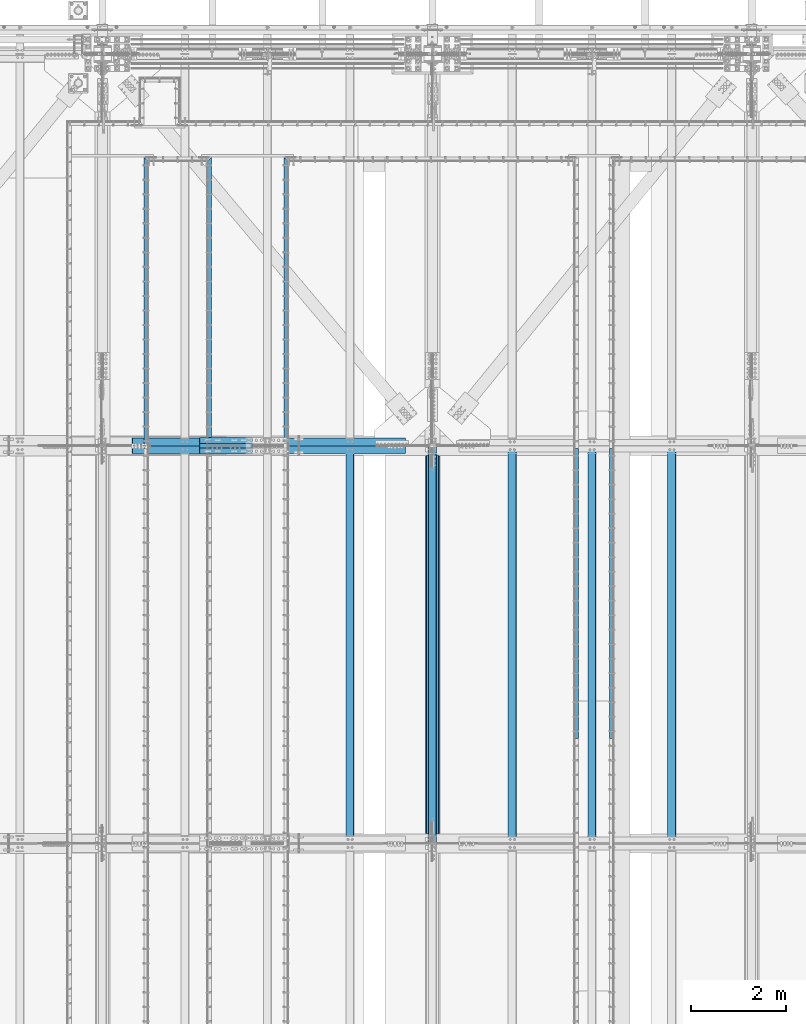
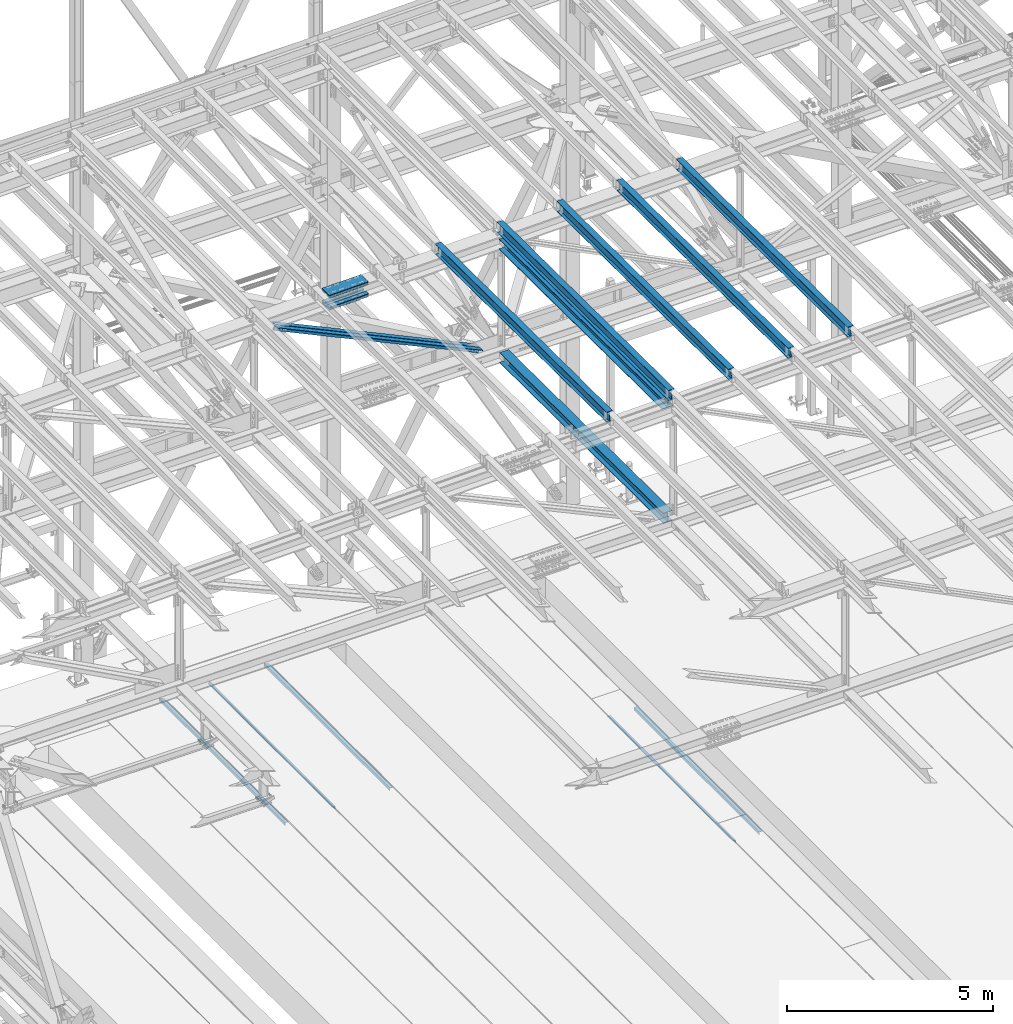
# One storey, part 1910 of 3843: 18 beams, 2 members, 15 elements without a shape of their own.
"""IFC2X3 building model written with IfcOpenShell, lengths in millimetres."""

from ifc_helpers import new_model, si_unit, frame, origin_with_axes, place, context, subcontext, project, spatial, faceted_brep, material, type_object, element, aggregate, save


model = new_model("IFC2X3")

# Units and contexts
model_context = context("Model", 3, precision=1e-05, world=origin_with_axes())
body_context = subcontext(model_context, "Body", "Model", "MODEL_VIEW")
ifc_project = project(units=[si_unit("LENGTHUNIT", "METRE", prefix="MILLI"), si_unit("AREAUNIT", "SQUARE_METRE"), si_unit("VOLUMEUNIT", "CUBIC_METRE"), si_unit("MASSUNIT", "GRAM", prefix="KILO"), si_unit("TIMEUNIT", "SECOND"), si_unit("PLANEANGLEUNIT", "RADIAN"), si_unit("SOLIDANGLEUNIT", "STERADIAN"), si_unit("THERMODYNAMICTEMPERATUREUNIT", "DEGREE_CELSIUS"), si_unit("LUMINOUSINTENSITYUNIT", "LUMEN")], contexts=[model_context])

# Site, building, storey
site_placement = place(None, origin_with_axes())
site = spatial("IfcSite", under=ifc_project, at=site_placement, CompositionType="ELEMENT")
building_placement = place(site_placement, origin_with_axes())
building = spatial("IfcBuilding", under=site, at=building_placement, Name="Undefined", CompositionType="ELEMENT")
storey_placement = place(building_placement, origin_with_axes())
storey = spatial("IfcBuildingStorey", under=building, at=storey_placement, Name="Undefined", CompositionType="ELEMENT", Elevation=0.0)

# Assembly, beam
assembly_1_placement = place(storey_placement, origin_with_axes())
assembly_1 = element("IfcElementAssembly", 1, at=assembly_1_placement, inside=storey, Name="EMBED_ANGLE", AssemblyPlace="NOTDEFINED", PredefinedType="RIGID_FRAME")
ifc_material_1 = material(Name="STEEL/A36")
beam_type_1 = type_object("IfcBeamType", Name="L3-1/2X3-1/2X5/16", PredefinedType="NOTDEFINED")
beam_1_placement = place(assembly_1_placement, frame((59697.1121396484, 83927.8223125, 30410.15), z_axis=(0.0, 0.0, -1.0), x_axis=(0.0, -1.0, 0.0)))
beam_1 = element("IfcBeam", 2, at=beam_1_placement, type_object=beam_type_1, material=ifc_material_1, Name="EMBED_ANGLE", ObjectType="L3-1/2X3-1/2X5/16", context=body_context, shape_type="Brep", body=[
    faceted_brep([(-3.63797880709171e-12, 44.4499999999971, -44.4500000000007), (-3.63797880709171e-12, 44.4499999999971, 44.4500000000007), (6096.0, 44.4499999999971, 44.4500000000007), (6096.0, 44.4499999999971, -44.4500000000007), (-3.63797880709171e-12, 36.5124999999971, 44.4500000000007), (6096.0, 36.5124999999971, 44.4500000000007), (-3.63797880709171e-12, 36.5124999999971, -36.5125000000007), (6096.0, 36.5124999999971, -36.5125000000007), (3.63797880709171e-12, -44.4499999999971, -36.5125000000007), (6096.0, -44.4499999999971, -36.5125000000007), (3.63797880709171e-12, -44.4499999999971, -44.4500000000007), (6096.0, -44.4499999999971, -44.4500000000007)], [[[0, 1, 2, 3]], [[1, 4, 5, 2]], [[4, 6, 7, 5]], [[6, 8, 9, 7]], [[8, 10, 11, 9]], [[10, 0, 3, 11]], [[5, 7, 9, 11, 3, 2]], [[10, 8, 6, 4, 1, 0]]]),
])
aggregate(assembly_1, [beam_1])

assembly_2_placement = place(storey_placement, origin_with_axes())
assembly_2 = element("IfcElementAssembly", 3, at=assembly_2_placement, inside=storey, Name="EMBED_ANGLE", AssemblyPlace="NOTDEFINED", PredefinedType="RIGID_FRAME")
beam_2_placement = place(assembly_2_placement, frame((58947.8753603516, 77831.8223125, 30410.15), z_axis=(0.0, 0.0, -1.0), x_axis=(0.0, 1.0, 0.0)))
beam_2 = element("IfcBeam", 4, at=beam_2_placement, type_object=beam_type_1, material=ifc_material_1, Name="EMBED_ANGLE", ObjectType="L3-1/2X3-1/2X5/16", context=body_context, shape_type="Brep", body=[
    faceted_brep([(-3.63797880709171e-12, 44.4499999999971, -44.4500000000007), (-3.63797880709171e-12, 44.4499999999971, 44.4500000000007), (6096.0, 44.4499999999971, 44.4500000000007), (6096.0, 44.4499999999971, -44.4500000000007), (-3.63797880709171e-12, 36.5124999999971, 44.4500000000007), (6096.0, 36.5124999999971, 44.4500000000007), (-3.63797880709171e-12, 36.5124999999971, -36.5125000000007), (6096.0, 36.5124999999971, -36.5125000000007), (3.63797880709171e-12, -44.4499999999971, -36.5125000000007), (6096.0, -44.4499999999971, -36.5125000000007), (3.63797880709171e-12, -44.4499999999971, -44.4500000000007), (6096.0, -44.4499999999971, -44.4500000000007)], [[[0, 1, 2, 3]], [[1, 4, 5, 2]], [[4, 6, 7, 5]], [[6, 8, 9, 7]], [[8, 10, 11, 9]], [[10, 0, 3, 11]], [[5, 7, 9, 11, 3, 2]], [[10, 8, 6, 4, 1, 0]]]),
])
aggregate(assembly_2, [beam_2])

assembly_3_placement = place(storey_placement, origin_with_axes())
assembly_3 = element("IfcElementAssembly", 5, at=assembly_3_placement, inside=storey, Name="EMBED_ANGLE", AssemblyPlace="NOTDEFINED", PredefinedType="RIGID_FRAME")
beam_3_placement = place(assembly_3_placement, frame((52851.812, 90049.2223125, 30410.15), z_axis=(0.0, 0.0, -1.0), x_axis=(0.0, -1.0, 0.0)))
beam_3 = element("IfcBeam", 6, at=beam_3_placement, type_object=beam_type_1, material=ifc_material_1, Name="EMBED_ANGLE", ObjectType="L3-1/2X3-1/2X5/16", context=body_context, shape_type="Brep", body=[
    faceted_brep([(-3.63797880709171e-12, 44.4499999999971, -44.4500000000007), (-3.63797880709171e-12, 44.4499999999971, 44.4500000000007), (6121.399609375, 44.4499999999971, 44.4500000000007), (6121.399609375, 44.4499999999971, -44.4500000000007), (7.93750032749085, 36.5124999999825, 44.4500000000007), (6121.399609375, 36.5124999999971, 44.4500000000007), (7.93749960740388, 36.5125000000007, -36.5124999999825), (6121.399609375, 36.5124999999971, -36.5125000000007), (88.9000039503298, -44.4500000001644, -36.5125000000007), (6121.399609375, -44.4499999999971, -36.5125000000007), (88.8999999971129, -44.4500000000007, -44.4499999999971), (6121.399609375, -44.4499999999971, -44.4500000000007)], [[[0, 1, 2, 3]], [[1, 4, 5, 2]], [[4, 6, 7, 5]], [[6, 8, 9, 7]], [[8, 10, 11, 9]], [[10, 0, 3, 11]], [[5, 7, 9, 11, 3, 2]], [[10, 8, 6, 4, 1, 0]]]),
])
aggregate(assembly_3, [beam_3])

assembly_4_placement = place(storey_placement, origin_with_axes())
assembly_4 = element("IfcElementAssembly", 7, at=assembly_4_placement, inside=storey, Name="EMBED_ANGLE", AssemblyPlace="NOTDEFINED", PredefinedType="RIGID_FRAME")
beam_4_placement = place(assembly_4_placement, frame((51238.9754423828, 83927.8227032043, 30410.15), z_axis=(0.0, 0.0, -1.0), x_axis=(0.0, 1.0, 0.0)))
beam_4 = element("IfcBeam", 8, at=beam_4_placement, type_object=beam_type_1, material=ifc_material_1, Name="EMBED_ANGLE", ObjectType="L3-1/2X3-1/2X5/16", context=body_context, shape_type="Brep", body=[
    faceted_brep([(-3.63797880709171e-12, 44.4499999999971, -44.4500000000007), (-3.63797880709171e-12, 44.4499999999971, 44.4500000000007), (6121.40035257449, 44.4500000054322, 44.4500000000007), (6121.40035257449, 44.4500000054322, -44.4500000000007), (-3.63797880709171e-12, 36.5124999999971, 44.4500000000007), (6113.46285058952, 36.5125000054322, 44.4500000000007), (-3.63797880709171e-12, 36.5124999999971, -36.5125000000007), (6113.46285058952, 36.5125000054322, -36.5125000000007), (3.63797880709171e-12, -44.4499999999971, -36.5125000000007), (6032.5003303429, -44.449999994642, -36.5125000000007), (3.63797880709171e-12, -44.4499999999971, -44.4500000000007), (6032.5003303429, -44.449999994642, -44.4500000000007)], [[[0, 1, 2, 3]], [[1, 4, 5, 2]], [[4, 6, 7, 5]], [[6, 8, 9, 7]], [[8, 10, 11, 9]], [[10, 0, 3, 11]], [[5, 7, 9, 11, 3, 2]], [[10, 8, 6, 4, 1, 0]]]),
])
aggregate(assembly_4, [beam_4])

assembly_5_placement = place(storey_placement, origin_with_axes())
assembly_5 = element("IfcElementAssembly", 9, at=assembly_5_placement, inside=storey, Name="EMBED_ANGLE", AssemblyPlace="NOTDEFINED", PredefinedType="RIGID_FRAME")
beam_5_placement = place(assembly_5_placement, frame((49911.7620576172, 90049.222703125, 30410.15), z_axis=(0.0, 0.0, -1.0), x_axis=(0.0, -1.0, 0.0)))
beam_5 = element("IfcBeam", 10, at=beam_5_placement, type_object=beam_type_1, material=ifc_material_1, Name="EMBED_ANGLE", ObjectType="L3-1/2X3-1/2X5/16", context=body_context, shape_type="Brep", body=[
    faceted_brep([(-3.63797880709171e-12, 44.4499999999971, -44.4500000000007), (-3.63797880709171e-12, 44.4499999999971, 44.4500000000007), (6121.39999960882, 44.4499999836771, 44.4500000000007), (6121.39999960882, 44.4499999836771, -44.4500000000007), (7.93750032749085, 36.5124999999825, 44.4500000000007), (6121.40000000021, 36.5125000042681, 44.4500000000007), (7.93749960740388, 36.5125000000007, -36.5124999999825), (6121.40000000021, 36.5125000042681, -36.5125000000007), (88.9000039503298, -44.4500000001644, -36.5125000000007), (6121.39999999969, -44.4499999957334, -36.5125000000007), (88.8999999971129, -44.4500000000007, -44.4499999999971), (6121.39999999969, -44.4499999957334, -44.4500000000007)], [[[0, 1, 2, 3]], [[1, 4, 5, 2]], [[4, 6, 7, 5]], [[6, 8, 9, 7]], [[8, 10, 11, 9]], [[10, 0, 3, 11]], [[5, 7, 9, 11, 3, 2]], [[10, 8, 6, 4, 1, 0]]]),
])
aggregate(assembly_5, [beam_5])

assembly_6_placement = place(storey_placement, origin_with_axes())
assembly_6 = element("IfcElementAssembly", 11, at=assembly_6_placement, inside=storey, Name="BEAM", AssemblyPlace="NOTDEFINED", PredefinedType="RIGID_FRAME")
ifc_material_2 = material(Name="STEEL/A992")
beam_type_2 = type_object("IfcBeamType", Name="W12X26", PredefinedType="NOTDEFINED")
beam_6_placement = place(assembly_6_placement, frame((55927.5092623212, 75629.6205146687, 46052.9384035833), z_axis=(-0.0211520978883419, 0.00720240799905153, 0.999750325868383), x_axis=(0.0, 0.999974055818778, -0.00720331099869441)))
beam_6 = element("IfcBeam", 12, at=beam_6_placement, type_object=beam_type_2, material=ifc_material_2, Name="BEAM", ObjectType="W12X26", context=body_context, shape_type="Brep", body=[
    faceted_brep([(12.7129088647489, 82.5500000003813, -155.575000000026), (12.6443041460152, 82.5500000003449, -146.050000000032), (8344.0604983595, 82.5499999999593, -146.049999981915), (8344.12910307823, 82.5500000000029, -155.574999981909), (12.6322086584405, 3.1750000004904, -146.049999999865), (8344.04840287192, 3.17500000010477, -146.049999981755), (10.5283306172641, 3.17499999950087, 146.049999999908), (8341.94452483075, 3.17499999911524, 146.050000018018), (10.5404261048243, 82.5499999993554, 146.049999999741), (8341.95662031831, 82.5499999989697, 146.050000017858), (10.471821386076, 82.5499999993335, 155.574999999735), (8341.88801559956, 82.5499999989479, 155.575000017852), (10.4466627719667, -82.550000000374, 155.575000000084), (8341.86285698545, -82.5500000007596, 155.575000018194), (10.5152674907004, -82.5500000003376, 146.050000000083), (8341.93146170417, -82.5500000007232, 146.050000018207), (10.5273629782459, -3.17500000048312, 146.049999999923), (8341.94355719173, -3.17500000086875, 146.050000018033), (12.6312410194514, -3.17499999948632, -146.049999999857), (8344.04743523293, -3.17499999987194, -146.04999998174), (12.6191455318913, -82.5499999993481, -146.049999999683), (8344.03533974537, -82.5499999997337, -146.049999981573), (12.687750250625, -82.549999999319, -155.574999999684), (8344.10394446411, -82.5499999997046, -155.574999981567)], [[[0, 1, 2, 3]], [[1, 4, 5, 2]], [[4, 6, 7, 5]], [[6, 8, 9, 7]], [[8, 10, 11, 9]], [[10, 12, 13, 11]], [[12, 14, 15, 13]], [[14, 16, 17, 15]], [[16, 18, 19, 17]], [[18, 20, 21, 19]], [[20, 22, 23, 21]], [[22, 0, 3, 23]], [[5, 7, 9, 11, 13, 15, 17, 19, 21, 23, 3, 2]], [[22, 20, 18, 16, 14, 12, 10, 8, 6, 4, 1, 0]]]),
])
aggregate(assembly_6, [beam_6])

assembly_7_placement = place(storey_placement, origin_with_axes())
assembly_7 = element("IfcElementAssembly", 13, at=assembly_7_placement, inside=storey, Name="BEAM", AssemblyPlace="NOTDEFINED", PredefinedType="RIGID_FRAME")
beam_7_placement = place(assembly_7_placement, frame((60956.7092623411, 75629.7181112033, 46167.0100447123), z_axis=(-0.0211520976666943, 0.00782973599719117, 0.999745609642029), x_axis=(0.0, 0.999969333427607, -0.00783148800334909)))
beam_7 = element("IfcBeam", 14, at=beam_7_placement, type_object=beam_type_2, material=ifc_material_2, Name="BEAM", ObjectType="W12X26", context=body_context, shape_type="Brep", body=[
    faceted_brep([(12.7140627501794, 82.5500000006432, -155.575000000201), (12.6395030821586, 82.5500000006286, -146.050000000185), (8344.09498107103, 82.5499999992244, -146.049999981638), (8344.16956159224, 82.5499999992171, -155.574999981669), (12.6263554730685, 3.17500000020664, -146.050000000439), (8344.081832008, 3.17499999939901, -146.049999981828), (10.3391988883959, 3.17500000020664, 146.050000000418), (8341.79469602446, 3.17499999981374, 146.05000001895), (10.3523479514115, 82.5500000000393, 146.050000000607), (8341.8078450875, 82.5499999996537, 146.050000019139), (10.2777674302197, 82.5500000000538, 155.575000000637), (8341.7332645663, 82.5499999996682, 155.575000019169), (10.2504173791094, -82.54999999961, 155.575000000252), (8341.70591451519, -82.5500000000029, 155.575000018784), (10.3249979003158, -82.5499999996173, 146.050000000221), (8341.78049503639, -82.5500000000102, 146.050000018753), (10.3381469633314, -3.17499999978463, 146.05000000041), (8341.79364409942, -3.17500000017026, 146.050000018942), (12.6253036643466, -3.17499999984284, -146.050000000461), (8344.08078008295, -3.17500000059226, -146.049999981842), (12.6121560552565, -82.5500000002503, -146.050000000731), (8344.06763101992, -82.5500000004249, -146.049999982024), (12.6867157232773, -82.5500000002357, -155.575000000761), (8344.14221154111, -82.5500000004467, -155.574999982062)], [[[0, 1, 2, 3]], [[1, 4, 5, 2]], [[4, 6, 7, 5]], [[6, 8, 9, 7]], [[8, 10, 11, 9]], [[10, 12, 13, 11]], [[12, 14, 15, 13]], [[14, 16, 17, 15]], [[16, 18, 19, 17]], [[18, 20, 21, 19]], [[20, 22, 23, 21]], [[22, 0, 3, 23]], [[5, 7, 9, 11, 13, 15, 17, 19, 21, 23, 3, 2]], [[22, 20, 18, 16, 14, 12, 10, 8, 6, 4, 1, 0]]]),
])
aggregate(assembly_7, [beam_7])

assembly_8_placement = place(storey_placement, origin_with_axes())
assembly_8 = element("IfcElementAssembly", 15, at=assembly_8_placement, inside=storey, Name="BEAM", AssemblyPlace="NOTDEFINED", PredefinedType="RIGID_FRAME")
beam_8_placement = place(assembly_8_placement, frame((59280.3094951058, 75629.6949436721, 46129.4892637621), z_axis=(-0.0211520984461022, 0.00768082099843015, 0.999746764796024), x_axis=(-2.79999999073589e-08, 0.999970488854129, -0.00768253999887893)))
beam_8 = element("IfcBeam", 16, at=beam_8_placement, type_object=beam_type_2, material=ifc_material_2, Name="BEAM", ObjectType="W12X26", context=body_context, shape_type="Brep", body=[
    faceted_brep([(12.7137920251844, 82.5500000001412, -155.574999999459), (12.6406300500821, 82.550000000112, -146.049999999479), (8344.08650044369, 82.5499999819294, -146.049999972885), (8344.15966241878, 82.549999981944, -155.574999972858), (12.6277288641431, 3.17500000027212, -146.04999999961), (8344.07359925774, 3.17499998207495, -146.049999973016), (10.3840949609585, 3.17499999966094, 146.049999999683), (8341.8299653546, 3.17499998147832, 146.050000026284), (10.396996146912, 82.5499999995154, 146.049999999814), (8341.84286654054, 82.5499999813255, 146.050000026415), (10.3238341718243, 82.5499999994936, 155.574999999793), (8341.76970456543, 82.5499999813037, 155.575000026394), (10.2969997050241, -82.5500000001848, 155.574999999524), (8341.74287009868, -82.5500000183747, 155.575000026132), (10.3701616801554, -82.5500000001775, 146.049999999552), (8341.81603207377, -82.5500000183529, 146.050000026145), (10.3830628660944, -3.17500000032305, 146.049999999675), (8341.82893325972, -3.17500001851295, 146.050000026276), (12.6266967692645, -3.17499999972642, -146.049999999625), (8344.07256716288, -3.17500001790177, -146.049999973016), (12.6137955832965, -82.5499999995664, -146.049999999741), (8344.05966597692, -82.5500000177562, -146.049999973147), (12.6869575584133, -82.5499999995518, -155.574999999728), (8344.13282795202, -82.5500000177344, -155.57499997312)], [[[0, 1, 2, 3]], [[1, 4, 5, 2]], [[4, 6, 7, 5]], [[6, 8, 9, 7]], [[8, 10, 11, 9]], [[10, 12, 13, 11]], [[12, 14, 15, 13]], [[14, 16, 17, 15]], [[16, 18, 19, 17]], [[18, 20, 21, 19]], [[20, 22, 23, 21]], [[22, 0, 3, 23]], [[5, 7, 9, 11, 13, 15, 17, 19, 21, 23, 3, 2]], [[22, 20, 18, 16, 14, 12, 10, 8, 6, 4, 1, 0]]]),
])
aggregate(assembly_8, [beam_8])

assembly_9_placement = place(storey_placement, origin_with_axes())
assembly_9 = element("IfcElementAssembly", 17, at=assembly_9_placement, inside=storey, Name="BEAM", AssemblyPlace="NOTDEFINED", PredefinedType="RIGID_FRAME")
beam_9_placement = place(assembly_9_placement, frame((57603.9094950745, 75629.6623214729, 46091.4605475656), z_axis=(-0.0211520978175394, 0.00747113299851479, 0.999748353801913), x_axis=(-2.80000000065103e-08, 0.999972078202891, -0.00747280500151662)))
beam_9 = element("IfcBeam", 18, at=beam_9_placement, type_object=beam_type_2, material=ifc_material_2, Name="BEAM", ObjectType="W12X26", context=body_context, shape_type="Brep", body=[
    faceted_brep([(12.7134055675851, 82.5500000001266, -155.574999999881), (12.6422410433443, 82.5500000000975, -146.049999999872), (8344.07486968451, 82.5499999825988, -146.050000005518), (8344.14603420874, 82.5499999826134, -155.57500000552), (12.6296920214081, 3.17500000025757, -146.050000000134), (8344.06232066256, 3.17499998275161, -146.050000005765), (10.4473132781277, 3.17499999968277, 146.050000000148), (8341.87994191929, 3.17499998217681, 146.049999994495), (10.4598623000784, 82.54999999953, 146.050000000389), (8341.89249094123, 82.549999982024, 146.049999994757), (10.3886977758375, 82.5499999995154, 155.575000000405), (8341.82132641699, 82.5499999820022, 155.574999994766), (10.3625958101911, -82.550000000163, 155.574999999873), (8341.79522445137, -82.5500000176762, 155.574999994227), (10.4337603344466, -82.5500000001484, 146.049999999865), (8341.8663889756, -82.5500000176544, 146.049999994219), (10.4463093563827, -3.17500000030122, 146.050000000119), (8341.87893799755, -3.17500001781445, 146.04999999448), (12.6286880996486, -3.17499999972642, -146.050000000148), (8344.06131674083, -3.17500001723965, -146.050000005795), (12.6161390777124, -82.5499999995664, -146.050000000403), (8344.04876771889, -82.5500000170869, -146.050000006042), (12.6873036019533, -82.5499999995518, -155.575000000412), (8344.11993224312, -82.5500000170578, -155.575000006058)], [[[0, 1, 2, 3]], [[1, 4, 5, 2]], [[4, 6, 7, 5]], [[6, 8, 9, 7]], [[8, 10, 11, 9]], [[10, 12, 13, 11]], [[12, 14, 15, 13]], [[14, 16, 17, 15]], [[16, 18, 19, 17]], [[18, 20, 21, 19]], [[20, 22, 23, 21]], [[22, 0, 3, 23]], [[5, 7, 9, 11, 13, 15, 17, 19, 21, 23, 3, 2]], [[22, 20, 18, 16, 14, 12, 10, 8, 6, 4, 1, 0]]]),
])
aggregate(assembly_9, [beam_9])

assembly_10_placement = place(storey_placement, origin_with_axes())
assembly_10 = element("IfcElementAssembly", 19, at=assembly_10_placement, inside=storey, Name="BEAM", AssemblyPlace="NOTDEFINED", PredefinedType="RIGID_FRAME")
beam_10_placement = place(assembly_10_placement, frame((54193.9592623106, 75629.5682799635, 46012.619349654), z_axis=(-0.0211520979096022, 0.00686665600215201, 0.99975268831315), x_axis=(0.0, 0.999976413691183, -0.00686819199787884)))
beam_10 = element("IfcBeam", 20, at=beam_10_placement, type_object=beam_type_2, material=ifc_material_2, Name="BEAM", ObjectType="W12X26", context=body_context, shape_type="Brep", body=[
    faceted_brep([(12.7122923707793, 82.5499999995809, -155.574999999801), (12.6468859356828, 82.5499999996027, -146.049999999792), (8344.0433927776, 82.5499999990498, -146.049999973708), (8344.1087992127, 82.5499999990279, -155.574999973716), (12.6353543282603, 3.17499999974098, -146.050000000068), (8344.03186117018, 3.174999999188, -146.049999973977), (10.6295569848153, 3.17500000024302, 146.050000000163), (8342.02606382675, 3.17499999969004, 146.050000026262), (10.6410885922378, 82.5500000000975, 146.050000000432), (8342.03759543417, 82.5499999995445, 146.050000026524), (10.5756821571267, 82.5500000001193, 155.575000000448), (8341.97218899905, 82.5499999995736, 155.575000026533), (10.5516964137059, -82.5499999995955, 155.574999999881), (8341.94820325564, -82.5500000001484, 155.575000025972), (10.617102848817, -82.54999999961, 146.049999999872), (8342.01360969074, -82.550000000163, 146.050000025964), (10.6286344562395, -3.17499999974825, 146.050000000141), (8342.02514129816, -3.17500000030122, 146.050000026233), (12.63443179967, -3.17500000025757, -146.05000000009), (8344.03093864159, -3.17500000081054, -146.049999974006), (12.6229001922475, -82.550000000112, -146.050000000359), (8344.01940703418, -82.550000000665, -146.049999974275), (12.6883066273731, -82.5500000001339, -155.575000000375), (8344.08481346929, -82.5500000006796, -155.574999974277)], [[[0, 1, 2, 3]], [[1, 4, 5, 2]], [[4, 6, 7, 5]], [[6, 8, 9, 7]], [[8, 10, 11, 9]], [[10, 12, 13, 11]], [[12, 14, 15, 13]], [[14, 16, 17, 15]], [[16, 18, 19, 17]], [[18, 20, 21, 19]], [[20, 22, 23, 21]], [[22, 0, 3, 23]], [[5, 7, 9, 11, 13, 15, 17, 19, 21, 23, 3, 2]], [[22, 20, 18, 16, 14, 12, 10, 8, 6, 4, 1, 0]]]),
])
aggregate(assembly_10, [beam_10])

# Assembly, beams
assembly_11_placement = place(storey_placement, origin_with_axes())
assembly_11 = element("IfcElementAssembly", 21, at=assembly_11_placement, inside=storey, Name="BEAM", AssemblyPlace="NOTDEFINED", PredefinedType="RIGID_FRAME")
ifc_material_3 = material(Name="STEEL/A572-50")
beam_type_3 = type_object("IfcBeamType", PredefinedType="NOTDEFINED")
beam_11_placement = place(assembly_11_placement, frame((51042.5320277706, 83870.8, 45386.8526639616), z_axis=(0.0, 1.0, 0.0), x_axis=(0.999765952267441, 0.0, 0.0216342480057898)))
beam_11 = element("IfcBeam", 22, at=beam_11_placement, type_object=beam_type_3, material=ifc_material_3, Name="PLATE", context=body_context, shape_type="Brep", body=[
    faceted_brep([(-4.36557456851006e-11, 12.7000000000116, -63.5), (-4.36557456851006e-11, 12.7000000000116, 63.5), (1104.90000001677, 12.7000000017251, 63.5), (1104.90000001677, 12.7000000017251, -63.5), (1.45519152283669e-11, -12.700000000008, 63.5), (1104.90000001682, -12.6999999982909, 63.5), (1.45519152283669e-11, -12.700000000008, -63.5), (1104.90000001682, -12.6999999982909, -63.5)], [[[0, 1, 2, 3]], [[1, 4, 5, 2]], [[4, 6, 7, 5]], [[6, 0, 3, 7]], [[5, 7, 3, 2]], [[6, 4, 1, 0]]]),
])
beam_12_placement = place(assembly_11_placement, frame((51036.1439752373, 83870.8, 45682.0585533749), z_axis=(0.0, 1.0, 0.0), x_axis=(0.999765952267441, 0.0, 0.0216342480057898)))
beam_12 = element("IfcBeam", 23, at=beam_12_placement, type_object=beam_type_3, material=ifc_material_3, Name="PLATE", context=body_context, shape_type="Brep", body=[
    faceted_brep([(-4.36557456851006e-11, 12.7000000000116, -63.5), (-4.36557456851006e-11, 12.7000000000116, 63.5), (1104.90000001677, 12.7000000017251, 63.5), (1104.90000001677, 12.7000000017251, -63.5), (1.45519152283669e-11, -12.700000000008, 63.5), (1104.90000001682, -12.6999999982909, 63.5), (1.45519152283669e-11, -12.700000000008, -63.5), (1104.90000001682, -12.6999999982909, -63.5)], [[[0, 1, 2, 3]], [[1, 4, 5, 2]], [[4, 6, 7, 5]], [[6, 0, 3, 7]], [[5, 7, 3, 2]], [[6, 4, 1, 0]]]),
])
beam_13_placement = place(assembly_11_placement, frame((51042.5320277706, 84099.4, 45386.8526639616), z_axis=(0.0, 1.0, 0.0), x_axis=(0.999765952267441, 0.0, 0.0216342480057898)))
beam_13 = element("IfcBeam", 24, at=beam_13_placement, type_object=beam_type_3, material=ifc_material_3, Name="PLATE", context=body_context, shape_type="Brep", body=[
    faceted_brep([(-4.36557456851006e-11, 12.7000000000116, -63.5), (-4.36557456851006e-11, 12.7000000000116, 63.5), (1104.90000001677, 12.7000000017251, 63.5), (1104.90000001677, 12.7000000017251, -63.5), (1.45519152283669e-11, -12.700000000008, 63.5), (1104.90000001682, -12.6999999982909, 63.5), (1.45519152283669e-11, -12.700000000008, -63.5), (1104.90000001682, -12.6999999982909, -63.5)], [[[0, 1, 2, 3]], [[1, 4, 5, 2]], [[4, 6, 7, 5]], [[6, 0, 3, 7]], [[5, 7, 3, 2]], [[6, 4, 1, 0]]]),
])
beam_14_placement = place(assembly_11_placement, frame((51036.1439752373, 84099.4, 45682.0585533749), z_axis=(0.0, 1.0, 0.0), x_axis=(0.999765952267441, 0.0, 0.0216342480057898)))
beam_14 = element("IfcBeam", 25, at=beam_14_placement, type_object=beam_type_3, material=ifc_material_3, Name="PLATE", context=body_context, shape_type="Brep", body=[
    faceted_brep([(-4.36557456851006e-11, 12.7000000000116, -63.5), (-4.36557456851006e-11, 12.7000000000116, 63.5), (1104.90000001677, 12.7000000017251, 63.5), (1104.90000001677, 12.7000000017251, -63.5), (1.45519152283669e-11, -12.700000000008, 63.5), (1104.90000001682, -12.6999999982909, 63.5), (1.45519152283669e-11, -12.700000000008, -63.5), (1104.90000001682, -12.6999999982909, -63.5)], [[[0, 1, 2, 3]], [[1, 4, 5, 2]], [[4, 6, 7, 5]], [[6, 0, 3, 7]], [[5, 7, 3, 2]], [[6, 4, 1, 0]]]),
])
beam_type_4 = type_object("IfcBeamType", PredefinedType="NOTDEFINED")
beam_15_placement = place(assembly_11_placement, frame((52148.5128588741, 83985.1, 45348.858332913), z_axis=(0.0, 1.0, 0.0), x_axis=(-0.999765952267441, 0.0, -0.0216342480057875)))
beam_15 = element("IfcBeam", 26, at=beam_15_placement, type_object=beam_type_4, material=ifc_material_3, Name="PLATE", context=body_context, shape_type="Brep", body=[
    faceted_brep([(-1.45519152283669e-11, 12.7000000000025, -177.800000000003), (-1.45519152283669e-11, 12.7000000000025, 177.800000000003), (1104.90000001682, 12.7000000017051, 177.800000000003), (1104.90000001682, 12.7000000017051, -177.800000000003), (4.36557456851006e-11, -12.7000000000171, 177.800000000003), (1104.90000001686, -12.6999999983072, 177.800000000003), (4.36557456851006e-11, -12.7000000000171, -177.800000000003), (1104.90000001686, -12.6999999983072, -177.800000000003)], [[[0, 1, 2, 3]], [[1, 4, 5, 2]], [[4, 6, 7, 5]], [[6, 0, 3, 7]], [[5, 7, 3, 2]], [[6, 4, 1, 0]]]),
])
beam_16_placement = place(assembly_11_placement, frame((52139.4459454884, 83985.1, 45767.8602456662), z_axis=(0.0, 1.0, 0.0), x_axis=(-0.999765952267441, 0.0, -0.0216342480057875)))
beam_16 = element("IfcBeam", 27, at=beam_16_placement, type_object=beam_type_4, material=ifc_material_3, Name="PLATE", context=body_context, shape_type="Brep", body=[
    faceted_brep([(-1.45519152283669e-11, 12.7000000000025, -177.800000000003), (-1.45519152283669e-11, 12.7000000000025, 177.800000000003), (1104.90000001682, 12.7000000017051, 177.800000000003), (1104.90000001682, 12.7000000017051, -177.800000000003), (4.36557456851006e-11, -12.7000000000171, 177.800000000003), (1104.90000001686, -12.6999999983072, 177.800000000003), (4.36557456851006e-11, -12.7000000000171, -177.800000000003), (1104.90000001686, -12.6999999983072, -177.800000000003)], [[[0, 1, 2, 3]], [[1, 4, 5, 2]], [[4, 6, 7, 5]], [[6, 0, 3, 7]], [[5, 7, 3, 2]], [[6, 4, 1, 0]]]),
])
aggregate(assembly_11, [beam_11, beam_12, beam_13, beam_14, beam_15, beam_16])

# Assembly, member
assembly_12_placement = place(storey_placement, origin_with_axes())
assembly_12 = element("IfcElementAssembly", 28, at=assembly_12_placement, inside=storey, Name="ANGLE", AssemblyPlace="NOTDEFINED", PredefinedType="RIGID_FRAME")
member_type = type_object("IfcMemberType", Name="L6X6X1/2", PredefinedType="NOTDEFINED")
member_1_placement = place(assembly_12_placement, frame((48996.6, 84070.825, 45490.3125590004), z_axis=(-0.422712133909736, 0.0, -0.906264007806488), x_axis=(0.906264007806487, 0.0, -0.422712133909738)))
member_1 = element("IfcMember", 29, at=member_1_placement, type_object=member_type, material=ifc_material_3, Name="ANGLE", ObjectType="L6X6X1/2", context=body_context, shape_type="Brep", body=[
    faceted_brep([(656.16028347586, 76.1999999999971, -76.2000000012631), (656.160283475856, 76.1999999999971, 76.1999999982509), (6993.20800429859, 76.1999999999971, 76.1999999837353), (6993.20800429859, 76.1999999999971, -76.2000000157786), (656.160283475856, 63.5, 76.1999999982509), (6993.20800429859, 63.5, 76.1999999837353), (656.160283475852, 63.5, -63.5000000013024), (6993.20800429859, 63.5, -63.5000000158179), (656.160283475852, -76.1999999999971, -63.5000000013024), (6993.20800429859, -76.1999999999971, -63.5000000158179), (656.16028347586, -76.1999999999971, -76.2000000012631), (6993.20800429859, -76.1999999999971, -76.2000000157786)], [[[0, 1, 2, 3]], [[1, 4, 5, 2]], [[4, 6, 7, 5]], [[6, 8, 9, 7]], [[8, 10, 11, 9]], [[10, 0, 3, 11]], [[5, 7, 9, 11, 3, 2]], [[10, 8, 6, 4, 1, 0]]]),
])
aggregate(assembly_12, [member_1])

assembly_13_placement = place(storey_placement, origin_with_axes())
assembly_13 = element("IfcElementAssembly", 30, at=assembly_13_placement, inside=storey, Name="ANGLE", AssemblyPlace="NOTDEFINED", PredefinedType="RIGID_FRAME")
member_2_placement = place(assembly_13_placement, frame((55930.7999996321, 83899.375, 42255.9675438683), z_axis=(-0.422712133909736, 0.0, -0.906264007806488), x_axis=(-0.906264007806486, 0.0, 0.42271213390974)))
member_2 = element("IfcMember", 31, at=member_2_placement, type_object=member_type, material=ifc_material_3, Name="ANGLE", ObjectType="L6X6X1/2", context=body_context, shape_type="Brep", body=[
    faceted_brep([(658.20476139781, 76.1999999999971, -76.1999999982581), (658.204761397814, 76.1999999999971, 76.2000000012486), (6995.25248222055, 76.1999999999971, 76.2000000157641), (6995.25248222055, 76.1999999999971, -76.1999999837499), (658.204761397814, 63.5, 76.2000000012486), (6995.25248222055, 63.5, 76.2000000157641), (658.20476139781, 63.5, -63.4999999983047), (6995.25248222054, 63.5, -63.4999999837892), (658.20476139781, -76.1999999999971, -63.4999999983047), (6995.25248222054, -76.1999999999971, -63.4999999837892), (658.20476139781, -76.1999999999971, -76.1999999982581), (6995.25248222055, -76.1999999999971, -76.1999999837499)], [[[0, 1, 2, 3]], [[1, 4, 5, 2]], [[4, 6, 7, 5]], [[6, 8, 9, 7]], [[8, 10, 11, 9]], [[10, 0, 3, 11]], [[5, 7, 9, 11, 3, 2]], [[10, 8, 6, 4, 1, 0]]]),
])
aggregate(assembly_13, [member_2])

# Assembly, beam
assembly_14_placement = place(storey_placement, origin_with_axes())
assembly_14 = element("IfcElementAssembly", 32, at=assembly_14_placement, inside=storey, Name="BEAM", AssemblyPlace="NOTDEFINED", PredefinedType="RIGID_FRAME")
beam_type_5 = type_object("IfcBeamType", Name="W12X65", PredefinedType="NOTDEFINED")
beam_17_placement = place(assembly_14_placement, frame((55930.8, 75628.4999999989, 45700.5002266971), z_axis=(0.0, 0.00720331099869509, 0.999974055818778), x_axis=(0.0, 0.999974055818778, -0.00720331099869441)))
beam_17 = element("IfcBeam", 33, at=beam_17_placement, type_object=beam_type_5, material=ifc_material_2, Name="BEAM", ObjectType="W12X65", context=body_context, shape_type="Brep", body=[
    faceted_brep([(213.83976774734, 152.400000000001, -153.987499999843), (213.725412218497, 152.400000000001, -138.112499999821), (8145.08118464809, 152.400000000001, -138.112499989009), (8145.19554017694, 152.400000000001, -153.987499989016), (213.725412218497, 4.76249999999709, -138.112499999821), (8145.08118464809, 4.76249999999709, -138.112499989009), (211.735626016525, 4.76249999999709, 138.112500000418), (8143.09139844612, 4.76249999999709, 138.112500011237), (211.735626016525, 152.400000000001, 138.112500000418), (8143.09139844612, 152.400000000001, 138.112500011237), (211.621270487682, 152.400000000001, 153.987500000432), (8142.97704291729, 152.400000000001, 153.987500011259), (211.621270487682, -152.400000000001, 153.987500000432), (8142.97704291729, -152.400000000001, 153.987500011259), (211.735626016525, -152.400000000001, 138.112500000418), (8143.09139844612, -152.400000000001, 138.112500011237), (211.735626016525, -4.76249999999709, 138.112500000418), (8143.09139844612, -4.76249999999709, 138.112500011237), (213.725412218497, -4.76249999999709, -138.112499999821), (8145.08118464809, -4.76249999999709, -138.112499989009), (213.725412218497, -152.400000000001, -138.112499999821), (8145.08118464809, -152.400000000001, -138.112499989009), (213.83976774734, -152.400000000001, -153.987499999843), (8145.19554017694, -152.400000000001, -153.987499989016)], [[[0, 1, 2, 3]], [[1, 4, 5, 2]], [[4, 6, 7, 5]], [[6, 8, 9, 7]], [[8, 10, 11, 9]], [[10, 12, 13, 11]], [[12, 14, 15, 13]], [[14, 16, 17, 15]], [[16, 18, 19, 17]], [[18, 20, 21, 19]], [[20, 22, 23, 21]], [[22, 0, 3, 23]], [[5, 7, 9, 11, 13, 15, 17, 19, 21, 23, 3, 2]], [[22, 20, 18, 16, 14, 12, 10, 8, 6, 4, 1, 0]]]),
])
aggregate(assembly_14, [beam_17])

assembly_15_placement = place(storey_placement, origin_with_axes())
assembly_15 = element("IfcElementAssembly", 34, at=assembly_15_placement, inside=storey, Name="BEAM", AssemblyPlace="NOTDEFINED", PredefinedType="RIGID_FRAME")
beam_type_6 = type_object("IfcBeamType", Name="W12X53", PredefinedType="NOTDEFINED")
beam_18_placement = place(assembly_15_placement, frame((55930.8, 75628.5, 42316.0749548714), z_axis=(0.0, 0.00720132700078831, 0.999974070108534), x_axis=(0.0, 0.999974070108534, -0.00720132700078161)))
beam_18 = element("IfcBeam", 35, at=beam_18_placement, type_object=beam_type_6, material=ifc_material_2, Name="BEAM", ObjectType="W12X53", context=body_context, shape_type="Brep", body=[
    faceted_brep([(199.540156288145, 127.0, -152.400000000744), (199.437264660548, 127.0, -138.112500000723), (8159.36866471908, 127.0, -138.112500024421), (8159.47155634666, 127.0, -152.400000024434), (199.437264660548, 4.76249999999709, -138.112500000723), (8159.36866471908, 4.76249999999709, -138.112500024421), (197.448026527025, 4.76249999999709, 138.112499999559), (8157.37942658554, 4.76249999999709, 138.112499975876), (197.448026527025, 127.0, 138.112499999559), (8157.37942658554, 127.0, 138.112499975876), (197.345134899442, 127.0, 152.399999999572), (8157.27653495794, 127.0, 152.399999975889), (197.345134899442, -127.0, 152.399999999572), (8157.27653495794, -127.0, 152.399999975889), (197.448026527025, -127.0, 138.112499999559), (8157.37942658554, -127.0, 138.112499975876), (197.448026527025, -4.76249999999709, 138.112499999559), (8157.37942658554, -4.76249999999709, 138.112499975876), (199.437264660548, -4.76249999999709, -138.112500000723), (8159.36866471908, -4.76249999999709, -138.112500024421), (199.437264660548, -127.0, -138.112500000723), (8159.36866471908, -127.0, -138.112500024421), (199.540156288145, -127.0, -152.400000000744), (8159.47155634666, -127.0, -152.400000024434)], [[[0, 1, 2, 3]], [[1, 4, 5, 2]], [[4, 6, 7, 5]], [[6, 8, 9, 7]], [[8, 10, 11, 9]], [[10, 12, 13, 11]], [[12, 14, 15, 13]], [[14, 16, 17, 15]], [[16, 18, 19, 17]], [[18, 20, 21, 19]], [[20, 22, 23, 21]], [[22, 0, 3, 23]], [[5, 7, 9, 11, 13, 15, 17, 19, 21, 23, 3, 2]], [[22, 20, 18, 16, 14, 12, 10, 8, 6, 4, 1, 0]]]),
])
aggregate(assembly_15, [beam_18])

save(model, "model.ifc")
